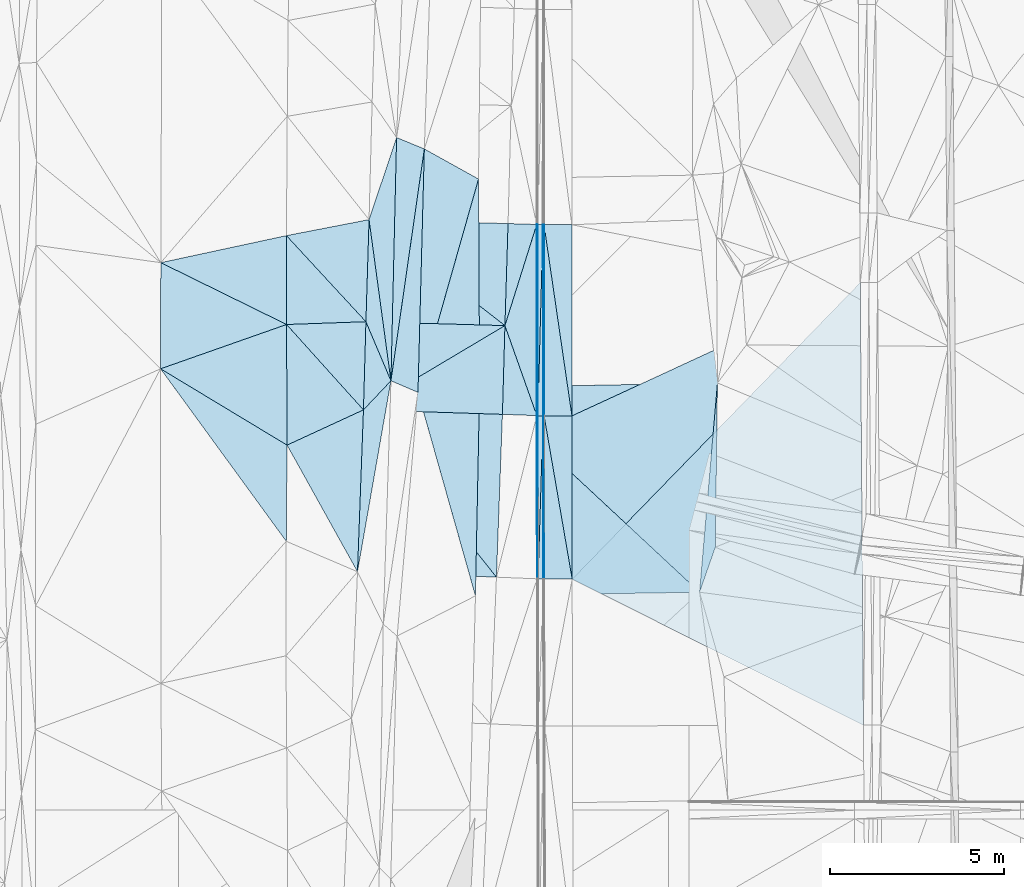
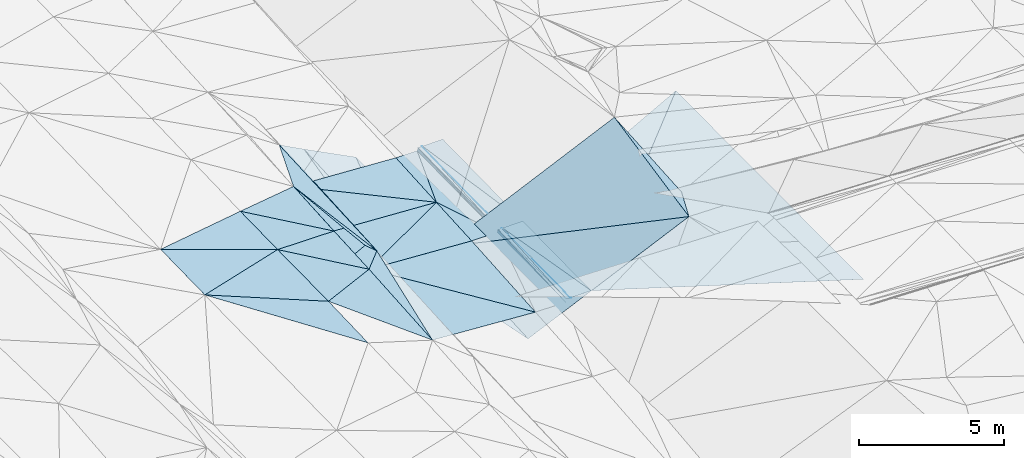
# One storey, part 110 of 275: 46 plates.
"""IFC2X3 building model written with IfcOpenShell, lengths in millimetres."""

from ifc_helpers import new_model, si_unit, frame, origin_with_axes, place, context, subcontext, project, spatial, polyline, outline, extrude, material, type_object, element, save


model = new_model("IFC2X3")

# Units and contexts
model_context = context("Model", 3, precision=1e-05, world=origin_with_axes())
body_context = subcontext(model_context, "Body", "Model", "MODEL_VIEW")
ifc_project = project(units=[si_unit("LENGTHUNIT", "METRE", prefix="MILLI"), si_unit("AREAUNIT", "SQUARE_METRE"), si_unit("VOLUMEUNIT", "CUBIC_METRE"), si_unit("MASSUNIT", "GRAM", prefix="KILO"), si_unit("TIMEUNIT", "SECOND"), si_unit("PLANEANGLEUNIT", "RADIAN"), si_unit("SOLIDANGLEUNIT", "STERADIAN"), si_unit("THERMODYNAMICTEMPERATUREUNIT", "DEGREE_CELSIUS"), si_unit("LUMINOUSINTENSITYUNIT", "LUMEN")], contexts=[model_context])

# Site, building, storey
site_placement = place(None, origin_with_axes())
site = spatial("IfcSite", under=ifc_project, at=site_placement, CompositionType="ELEMENT")
building_placement = place(site_placement, origin_with_axes())
building = spatial("IfcBuilding", under=site, at=building_placement, Name="Undefined", CompositionType="ELEMENT")
storey_placement = place(building_placement, origin_with_axes())
storey = spatial("IfcBuildingStorey", under=building, at=storey_placement, Name="Undefined", CompositionType="ELEMENT", Elevation=0.0)

# Plates
ifc_material = material()
plate_type_1 = type_object("IfcPlateType", PredefinedType="NOTDEFINED")
plate_1_placement = place(storey_placement, frame((-62445.3177072304, 83277.9958132401, 42809.5003490646), z_axis=(-0.0315854140654683, 0.0199617095165951, -0.999301702075749), x_axis=(0.999078721407139, -0.0284310420091758, -0.0321462949925501)))
element("IfcPlate", 1, at=plate_1_placement, inside=storey, type_object=plate_type_1, material=ifc_material, Name="00_PR", context=body_context, shape_type="SweptSolid", body=[
    extrude(outline(polyline([(0.0, 0.0), (4002.07861328125, -1.1743395589292e-08), (3997.42602539063, 2937.28759765625), (0.0, 0.0)])), frame((-8.85201319254618e-08, 2.18876761149539e-07, -0.5000001331573), z_axis=(0.0, 0.0, 1.0), x_axis=(1.0, 0.0, 0.0)), (0.0, 0.0, 1.0), 1.0),
])
plate_type_2 = type_object("IfcPlateType", PredefinedType="NOTDEFINED")
plate_2_placement = place(storey_placement, frame((-58536.9111922059, 80228.8299726045, 42625.0563495492), z_axis=(-0.0317222719708012, 0.0197862345419208, -0.999300856791218), x_axis=(-0.999087756710588, 0.0279704329910599, 0.0322693239671747)))
element("IfcPlate", 2, at=plate_2_placement, inside=storey, type_object=plate_type_2, material=ifc_material, Name="00_PR", context=body_context, shape_type="SweptSolid", body=[
    extrude(outline(polyline([(0.0, 0.0), (4002.09814453125, -4.45288605988026e-09), (3996.07958984375, 2939.119140625), (0.0, 0.0)])), frame((-8.85201319254618e-08, 2.18876761149539e-07, -0.5000001331573), z_axis=(0.0, 0.0, 1.0), x_axis=(1.0, 0.0, 0.0)), (0.0, 0.0, 1.0), 1.0),
])
plate_type_3 = type_object("IfcPlateType", PredefinedType="NOTDEFINED")
plate_3_placement = place(storey_placement, frame((-58536.9111922059, 80228.8299726045, 42625.0563495492), z_axis=(-0.0317247257780146, 0.0197004845342248, -0.999302473069804), x_axis=(-0.859075985348122, -0.511559405203103, 0.0171879709797397)))
element("IfcPlate", 3, at=plate_3_placement, inside=storey, type_object=plate_type_3, material=ifc_material, Name="00_PR", context=body_context, shape_type="SweptSolid", body=[
    extrude(outline(polyline([(0.0, 0.0), (4736.9755859375, -1.73604348674417e-08), (3379.92553710938, 2143.103515625), (0.0, 0.0)])), frame((-8.85201319254618e-08, 2.18876761149539e-07, -0.5000001331573), z_axis=(0.0, 0.0, 1.0), x_axis=(1.0, 0.0, 0.0)), (0.0, 0.0, 1.0), 1.0),
])
plate_type_4 = type_object("IfcPlateType", PredefinedType="NOTDEFINED")
plate_4_placement = place(storey_placement, frame((-62606.3332485193, 77805.5853230835, 42706.4753447277), z_axis=(-0.0315997411073619, 0.0194903227634184, -0.999310554172488), x_axis=(0.859075985348976, 0.511559405201546, -0.0171879709834169)))
element("IfcPlate", 4, at=plate_4_placement, inside=storey, type_object=plate_type_4, material=ifc_material, Name="00_PR", context=body_context, shape_type="SweptSolid", body=[
    extrude(outline(polyline([(0.0, 0.0), (4736.9755859375, -1.73604348674417e-08), (3370.44311523438, 2158.02124023438), (0.0, 0.0)])), frame((-8.85201319254618e-08, 2.18876761149539e-07, -0.5000001331573), z_axis=(0.0, 0.0, 1.0), x_axis=(1.0, 0.0, 0.0)), (0.0, 0.0, 1.0), 1.0),
])
plate_type_5 = type_object("IfcPlateType", PredefinedType="NOTDEFINED")
plate_5_placement = place(storey_placement, frame((-62606.3332390002, 77805.5856066557, 42706.4753500687), z_axis=(-0.0315810358178752, 0.0200566956395045, -0.999299938525313), x_axis=(0.998955927695341, -0.0323869359934166, -0.032220193967445)))
element("IfcPlate", 5, at=plate_5_placement, inside=storey, type_object=plate_type_5, material=ifc_material, Name="00_PR", context=body_context, shape_type="SweptSolid", body=[
    extrude(outline(polyline([(0.0, 0.0), (4002.11743164063, -7.84348230808973e-09), (3984.26293945313, 4687.0849609375), (0.0, 0.0)])), frame((-8.85201319254618e-08, 2.18876761149539e-07, -0.5000001331573), z_axis=(0.0, 0.0, 1.0), x_axis=(1.0, 0.0, 0.0)), (0.0, 0.0, 1.0), 1.0),
])
plate_type_6 = type_object("IfcPlateType", PredefinedType="NOTDEFINED")
plate_6_placement = place(storey_placement, frame((-57621.6868483666, 83138.9228194807, 42706.2017387824), z_axis=(0.970132635140627, 0.00490317513486907, -0.242525522592367), x_axis=(0.24230420795389, -0.0668225649493554, 0.967896386821145)))
element("IfcPlate", 6, at=plate_6_placement, inside=storey, type_object=plate_type_6, material=ifc_material, Name="00_PR", context=body_context, shape_type="SweptSolid", body=[
    extrude(outline(polyline([(0.0, 0.0), (123.791145324707, 3.05590219795704e-10), (273.008209228516, 5493.51953125), (0.0, 0.0)])), frame((-8.85201319254618e-08, 2.18876761149539e-07, -0.5000001331573), z_axis=(0.0, 0.0, 1.0), x_axis=(1.0, 0.0, 0.0)), (0.0, 0.0, 1.0), 1.0),
])
plate_type_7 = type_object("IfcPlateType", PredefinedType="NOTDEFINED")
plate_7_placement = place(storey_placement, frame((-57442.1709183714, 83130.164079048, 42825.6400820287), z_axis=(5.89384525256398e-05, 0.0179256504627519, -0.999839320881984), x_axis=(-0.0267601369903084, -0.999481235296596, -0.0179208079686884)))
element("IfcPlate", 7, at=plate_7_placement, inside=storey, type_object=plate_type_7, material=ifc_material, Name="00_PR", context=body_context, shape_type="SweptSolid", body=[
    extrude(outline(polyline([(0.0, 0.0), (5498.6357421875, 2.43016984313726e-09), (3.52122259140015, 149.96533203125), (0.0, 0.0)])), frame((-8.85201319254618e-08, 2.18876761149539e-07, -0.5000001331573), z_axis=(0.0, 0.0, 1.0), x_axis=(1.0, 0.0, 0.0)), (0.0, 0.0, 1.0), 1.0),
])
plate_8_placement = place(storey_placement, frame((-57438.9691726455, 77630.850453566, 42727.1000792408), z_axis=(0.000413148946733907, 0.0175960180344832, -0.999845092730508), x_axis=(-0.0305274379987929, -0.999378957367669, -0.0176004289703739)))
element("IfcPlate", 8, at=plate_8_placement, inside=storey, type_object=plate_type_7, material=ifc_material, Name="00_PR", context=body_context, shape_type="SweptSolid", body=[
    extrude(outline(polyline([(0.0, 0.0), (4695.51025390625, -1.80443748831749e-09), (1.0617915391922, 150.383514404297), (0.0, 0.0)])), frame((-8.85201319254618e-08, 2.18876761149539e-07, -0.5000001331573), z_axis=(0.0, 0.0, 1.0), x_axis=(1.0, 0.0, 0.0)), (0.0, 0.0, 1.0), 1.0),
])
plate_9_placement = place(storey_placement, frame((-57589.3149893711, 77634.3806865003, 42727.1000829347), z_axis=(0.000420660970530861, 0.0179159672540696, -0.999839407685904), x_axis=(0.0267601369728384, 0.999481235297007, 0.0179208079718514)))
element("IfcPlate", 9, at=plate_9_placement, inside=storey, type_object=plate_type_7, material=ifc_material, Name="00_PR", context=body_context, shape_type="SweptSolid", body=[
    extrude(outline(polyline([(0.0, 0.0), (5498.6357421875, 2.43016984313726e-09), (0.495032548904419, 150.386444091797), (0.0, 0.0)])), frame((-8.85201319254618e-08, 2.18876761149539e-07, -0.5000001331573), z_axis=(0.0, 0.0, 1.0), x_axis=(1.0, 0.0, 0.0)), (0.0, 0.0, 1.0), 1.0),
])
plate_10_placement = place(storey_placement, frame((-57582.3112025152, 72938.256117177, 42644.4570800898), z_axis=(0.000165261124698532, 0.0176035890359475, -0.999845031163237), x_axis=(0.0305274379744669, 0.999378957368358, 0.0176004289734247)))
element("IfcPlate", 10, at=plate_10_placement, inside=storey, type_object=plate_type_7, material=ifc_material, Name="00_PR", context=body_context, shape_type="SweptSolid", body=[
    extrude(outline(polyline([(0.0, 0.0), (4695.51025390625, -1.80443748831749e-09), (3.17336273193359, 150.046966552734), (0.0, 0.0)])), frame((-8.85201319254618e-08, 2.18876761149539e-07, -0.5000001331573), z_axis=(0.0, 0.0, 1.0), x_axis=(1.0, 0.0, 0.0)), (0.0, 0.0, 1.0), 1.0),
])
plate_type_8 = type_object("IfcPlateType", PredefinedType="NOTDEFINED")
plate_11_placement = place(storey_placement, frame((-57412.1606591374, 83130.1678266421, 42826.2401807814), z_axis=(0.0199903537948157, 0.0179238670003868, -0.999639495391669), x_axis=(0.000582077023911747, -0.999839329562212, -0.0179158099712417)))
element("IfcPlate", 11, at=plate_11_placement, inside=storey, type_object=plate_type_8, material=ifc_material, Name="00_PR", context=body_context, shape_type="SweptSolid", body=[
    extrude(outline(polyline([(0.0, 0.0), (5500.169921875, -1.15178409032524e-08), (-0.00296620349399745, 30.0062942504883), (0.0, 0.0)])), frame((-8.85201319254618e-08, 2.18876761149539e-07, -0.5000001331573), z_axis=(0.0, 0.0, 1.0), x_axis=(1.0, 0.0, 0.0)), (0.0, 0.0, 1.0), 1.0),
])
plate_12_placement = place(storey_placement, frame((-57438.9593939027, 77630.8506163562, 42727.1001824236), z_axis=(0.0199741401845531, 0.0179238633719823, -0.99963981955788), x_axis=(-0.000582077026000538, 0.999839329562174, 0.0179158099732483)))
element("IfcPlate", 12, at=plate_12_placement, inside=storey, type_object=plate_type_8, material=ifc_material, Name="00_PR", context=body_context, shape_type="SweptSolid", body=[
    extrude(outline(polyline([(0.0, 0.0), (5500.197265625, 1.87355908565223e-08), (0.0243410114198923, 30.006254196167), (0.0, 0.0)])), frame((-8.85201319254618e-08, 2.18876761149539e-07, -0.5000001331573), z_axis=(0.0, 0.0, 1.0), x_axis=(1.0, 0.0, 0.0)), (0.0, 0.0, 1.0), 1.0),
])
plate_13_placement = place(storey_placement, frame((-57432.2273950733, 72936.8472443817, 42644.4571798821), z_axis=(0.0199607529985949, 0.0176285553389435, -0.999645338295733), x_axis=(-0.00143400902612084, 0.999844019358452, 0.0176034249863106)))
element("IfcPlate", 13, at=plate_13_placement, inside=storey, type_object=plate_type_8, material=ifc_material, Name="00_PR", context=body_context, shape_type="SweptSolid", body=[
    extrude(outline(polyline([(0.0, 0.0), (4694.7353515625, -2.56914063356817e-08), (0.0227603428065777, 30.0065383911133), (0.0, 0.0)])), frame((-8.85201319254618e-08, 2.18876761149539e-07, -0.5000001331573), z_axis=(0.0, 0.0, 1.0), x_axis=(1.0, 0.0, 0.0)), (0.0, 0.0, 1.0), 1.0),
])
plate_type_9 = type_object("IfcPlateType", PredefinedType="NOTDEFINED")
plate_14_placement = place(storey_placement, frame((-62777.9336882094, 73148.5209642545, 42619.5003912758), z_axis=(-0.0343608174188855, 0.0205760651535635, -0.999197658008215), x_axis=(0.0368151613526759, 0.999135533976908, 0.0193087710446821)))
element("IfcPlate", 14, at=plate_14_placement, inside=storey, type_object=plate_type_9, material=ifc_material, Name="00", context=body_context, shape_type="SweptSolid", body=[
    extrude(outline(polyline([(0.0, 0.0), (4661.09423828125, -3.13593773171306e-08), (5524.3896484375, 760.051635742188), (0.0, 0.0)])), frame((-8.85201319254618e-08, 2.18876761149539e-07, -0.5000001331573), z_axis=(0.0, 0.0, 1.0), x_axis=(1.0, 0.0, 0.0)), (0.0, 0.0, 1.0), 1.0),
])
plate_type_10 = type_object("IfcPlateType", PredefinedType="NOTDEFINED")
plate_15_placement = place(storey_placement, frame((-58536.8796844866, 80228.82903207, 42625.0563252699), z_axis=(0.0312885211238499, 0.0179011582431978, -0.999350077289953), x_axis=(0.299757488876868, 0.953648213534751, 0.0264675779815947)))
element("IfcPlate", 15, at=plate_15_placement, inside=storey, type_object=plate_type_10, material=ifc_material, Name="00_PR", context=body_context, shape_type="SweptSolid", body=[
    extrude(outline(polyline([(0.0, 0.0), (3051.544921875, -1.43772922456265e-08), (-2194.61279296875, 1652.61083984375), (0.0, 0.0)])), frame((-8.85201319254618e-08, 2.18876761149539e-07, -0.5000001331573), z_axis=(0.0, 0.0, 1.0), x_axis=(1.0, 0.0, 0.0)), (0.0, 0.0, 1.0), 1.0),
])
plate_type_11 = type_object("IfcPlateType", PredefinedType="NOTDEFINED")
plate_16_placement = place(storey_placement, frame((-57618.9634509243, 77639.5114144846, 42607.4133171386), z_axis=(0.0308418574531809, 0.0177429290790511, -0.999366783666804), x_axis=(-0.998866829280015, 0.0368055550354608, -0.0301729760319002)))
element("IfcPlate", 16, at=plate_16_placement, inside=storey, type_object=plate_type_11, material=ifc_material, Name="00_PR", context=body_context, shape_type="SweptSolid", body=[
    extrude(outline(polyline([(0.0, 0.0), (990.522094726563, -2.8085196390748e-09), (1011.64520263672, 2554.21630859375), (0.0, 0.0)])), frame((-8.85201319254618e-08, 2.18876761149539e-07, -0.5000001331573), z_axis=(0.0, 0.0, 1.0), x_axis=(1.0, 0.0, 0.0)), (0.0, 0.0, 1.0), 1.0),
])
plate_type_12 = type_object("IfcPlateType", PredefinedType="NOTDEFINED")
plate_17_placement = place(storey_placement, frame((-61653.2734745281, 85638.8519640096, 42845.5001881095), z_axis=(-0.0179682444485179, 0.0212709194481109, -0.999612269921328), x_axis=(-0.0231638574708815, -0.999514187364314, -0.0208524570380708)))
element("IfcPlate", 17, at=plate_17_placement, inside=storey, type_object=plate_type_12, material=ifc_material, Name="00", context=body_context, shape_type="SweptSolid", body=[
    extrude(outline(polyline([(0.0, 0.0), (7001.5732421875, 1.62908690981567e-08), (2378.80590820313, 737.252075195313), (0.0, 0.0)])), frame((-8.85201319254618e-08, 2.18876761149539e-07, -0.5000001331573), z_axis=(0.0, 0.0, 1.0), x_axis=(1.0, 0.0, 0.0)), (0.0, 0.0, 1.0), 1.0),
])
plate_type_13 = type_object("IfcPlateType", PredefinedType="NOTDEFINED")
plate_18_placement = place(storey_placement, frame((-58780.953297902, 72992.8645551217, 42488.9863514636), z_axis=(-0.0316714713469708, 0.0199847488422636, -0.99929851781959), x_axis=(-0.998716945625713, 0.0388934670209276, 0.0324308609682016)))
element("IfcPlate", 18, at=plate_18_placement, inside=storey, type_object=plate_type_13, material=ifc_material, Name="00_PR", context=body_context, shape_type="SweptSolid", body=[
    extrude(outline(polyline([(0.0, 0.0), (4002.11376953125, 1.0986695997417e-08), (4014.70849609375, 4661.033203125), (0.0, 0.0)])), frame((-8.85201319254618e-08, 2.18876761149539e-07, -0.5000001331573), z_axis=(0.0, 0.0, 1.0), x_axis=(1.0, 0.0, 0.0)), (0.0, 0.0, 1.0), 1.0),
])
plate_type_14 = type_object("IfcPlateType", PredefinedType="NOTDEFINED")
plate_19_placement = place(storey_placement, frame((-48315.5027158374, 81465.7256772161, 42977.9691787994), z_axis=(0.0199746350867167, 0.0177399018565916, -0.999643091225699), x_axis=(0.00717853003015854, -0.999819345250477, -0.0175995900382054)))
element("IfcPlate", 19, at=plate_19_placement, inside=storey, type_object=plate_type_14, material=ifc_material, Name="00_PR", context=body_context, shape_type="SweptSolid", body=[
    extrude(outline(polyline([(0.0, 0.0), (12734.5009765625, 5.47734089195728e-08), (8471.9130859375, 8349.4228515625), (0.0, 0.0)])), frame((-8.85201319254618e-08, 2.18876761149539e-07, -0.5000001331573), z_axis=(0.0, 0.0, 1.0), x_axis=(1.0, 0.0, 0.0)), (0.0, 0.0, 1.0), 1.0),
])
plate_type_15 = type_object("IfcPlateType", PredefinedType="NOTDEFINED")
plate_20_placement = place(storey_placement, frame((-56612.1606702907, 83130.2649938498, 42842.240181095), z_axis=(0.0199906118117103, 0.0179262639094457, -0.999639447251679), x_axis=(0.000581992979138998, -0.999839286621116, -0.0179182089827727)))
element("IfcPlate", 20, at=plate_20_placement, inside=storey, type_object=plate_type_15, material=ifc_material, Name="00_PR", context=body_context, shape_type="SweptSolid", body=[
    extrude(outline(polyline([(0.0, 0.0), (5499.43359375, -1.13941496238112e-08), (-0.0817527920007706, 800.159973144531), (0.0, 0.0)])), frame((-8.85201319254618e-08, 2.18876761149539e-07, -0.5000001331573), z_axis=(0.0, 0.0, 1.0), x_axis=(1.0, 0.0, 0.0)), (0.0, 0.0, 1.0), 1.0),
])
plate_21_placement = place(storey_placement, frame((-56608.9600476809, 77631.7152347256, 42743.7001784185), z_axis=(0.019974549832582, 0.0176309226597535, -0.999645020957516), x_axis=(0.00143405198738597, -0.999843977884378, -0.0176057769848715)))
element("IfcPlate", 21, at=plate_21_placement, inside=storey, type_object=plate_type_15, material=ifc_material, Name="00_PR", context=body_context, shape_type="SweptSolid", body=[
    extrude(outline(polyline([(0.0, 0.0), (4694.083984375, -9.2186382971704e-09), (-0.0319749563932419, 800.159484863281), (0.0, 0.0)])), frame((-8.85201319254618e-08, 2.18876761149539e-07, -0.5000001331573), z_axis=(0.0, 0.0, 1.0), x_axis=(1.0, 0.0, 0.0)), (0.0, 0.0, 1.0), 1.0),
])
plate_22_placement = place(storey_placement, frame((-57408.9591456549, 77630.8816770682, 42727.7001808687), z_axis=(0.0199741401845531, 0.0179238633719823, -0.99963981955788), x_axis=(-0.000582077026000538, 0.999839329562174, 0.0179158099732483)))
element("IfcPlate", 22, at=plate_22_placement, inside=storey, type_object=plate_type_15, material=ifc_material, Name="00_PR", context=body_context, shape_type="SweptSolid", body=[
    extrude(outline(polyline([(0.0, 0.0), (5500.169921875, -1.15178409032524e-08), (0.654560685157776, 800.159240722656), (0.0, 0.0)])), frame((-8.85201319254618e-08, 2.18876761149539e-07, -0.5000001331573), z_axis=(0.0, 0.0, 1.0), x_axis=(1.0, 0.0, 0.0)), (0.0, 0.0, 1.0), 1.0),
])
plate_23_placement = place(storey_placement, frame((-57402.2269020101, 72936.9025004294, 42645.0571785886), z_axis=(0.0199607529985949, 0.0176285553389435, -0.999645338295733), x_axis=(-0.00143400902612084, 0.999844019358452, 0.0176034249863106)))
element("IfcPlate", 23, at=plate_23_placement, inside=storey, type_object=plate_type_15, material=ifc_material, Name="00_PR", context=body_context, shape_type="SweptSolid", body=[
    extrude(outline(polyline([(0.0, 0.0), (4694.71142578125, 1.03318598121405e-08), (0.59520697593689, 800.159484863281), (0.0, 0.0)])), frame((-8.85201319254618e-08, 2.18876761149539e-07, -0.5000001331573), z_axis=(0.0, 0.0, 1.0), x_axis=(1.0, 0.0, 0.0)), (0.0, 0.0, 1.0), 1.0),
])
plate_type_16 = type_object("IfcPlateType", PredefinedType="NOTDEFINED")
plate_24_placement = place(storey_placement, frame((-56602.2284332541, 72938.3634596855, 42661.0571794938), z_axis=(0.0200866421434011, 0.0176310438425496, -0.999642772744556), x_axis=(-0.00143405199437201, 0.999843977884384, 0.0176057769839547)))
element("IfcPlate", 24, at=plate_24_placement, inside=storey, type_object=plate_type_16, material=ifc_material, Name="00_PR", context=body_context, shape_type="SweptSolid", body=[
    extrude(outline(polyline([(0.0, 0.0), (4694.083984375, -9.2186382971704e-09), (8519.7275390625, 8300.626953125), (0.0, 0.0)])), frame((-8.85201319254618e-08, 2.18876761149539e-07, -0.5000001331573), z_axis=(0.0, 0.0, 1.0), x_axis=(1.0, 0.0, 0.0)), (0.0, 0.0, 1.0), 1.0),
])
plate_type_17 = type_object("IfcPlateType", PredefinedType="NOTDEFINED")
plate_25_placement = place(storey_placement, frame((-57618.4935387309, 77639.5049537193, 42607.7928165393), z_axis=(0.970669872255005, 0.00481481324952325, -0.240368085797231), x_axis=(0.00487705397550587, 0.999199352706721, 0.0397097959575397)))
element("IfcPlate", 25, at=plate_25_placement, inside=storey, type_object=plate_type_17, material=ifc_material, Name="00_PR", context=body_context, shape_type="SweptSolid", body=[
    extrude(outline(polyline([(0.0, 0.0), (5495.5458984375, 3.20251274388283e-08), (-0.229290172457695, 123.414688110352), (0.0, 0.0)])), frame((-8.85201319254618e-08, 2.18876761149539e-07, -0.5000001331573), z_axis=(0.0, 0.0, 1.0), x_axis=(1.0, 0.0, 0.0)), (0.0, 0.0, 1.0), 1.0),
])
plate_26_placement = place(storey_placement, frame((-57588.8298611335, 77634.374543891, 42727.4798348147), z_axis=(0.970673892886174, 0.00563007462333887, -0.240334133923867), x_axis=(-0.0048865979847701, -0.99905707824968, -0.0431401849711931)))
element("IfcPlate", 26, at=plate_26_placement, inside=storey, type_object=plate_type_17, material=ifc_material, Name="00_PR", context=body_context, shape_type="SweptSolid", body=[
    extrude(outline(polyline([(0.0, 0.0), (4693.90673828125, 2.06455297302455e-08), (0.182295963168144, 123.414764404297), (0.0, 0.0)])), frame((-8.85201319254618e-08, 2.18876761149539e-07, -0.5000001331573), z_axis=(0.0, 0.0, 1.0), x_axis=(1.0, 0.0, 0.0)), (0.0, 0.0, 1.0), 1.0),
])
plate_type_18 = type_object("IfcPlateType", PredefinedType="NOTDEFINED")
plate_27_placement = place(storey_placement, frame((-57622.1565060754, 83138.929393828, 42705.8233191055), z_axis=(0.0308163268850978, 0.0180499146264711, -0.999362073814735), x_axis=(-0.299757488826495, -0.953648213551149, -0.0264675779612603)))
element("IfcPlate", 27, at=plate_27_placement, inside=storey, type_object=plate_type_18, material=ifc_material, Name="00_PR", context=body_context, shape_type="SweptSolid", body=[
    extrude(outline(polyline([(0.0, 0.0), (3051.544921875, -1.43772922456265e-08), (223.772232055664, 794.595764160156), (0.0, 0.0)])), frame((-8.85201319254618e-08, 2.18876761149539e-07, -0.5000001331573), z_axis=(0.0, 0.0, 1.0), x_axis=(1.0, 0.0, 0.0)), (0.0, 0.0, 1.0), 1.0),
])
plate_28_placement = place(storey_placement, frame((-60854.9814031236, 85311.7670170099, 42583.5244037562), z_axis=(-0.307417830822706, 0.0277280302770093, -0.951170559694327), x_axis=(-0.026118208484216, -0.999444646635945, -0.0206938999786211)))
element("IfcPlate", 28, at=plate_28_placement, inside=storey, type_object=plate_type_18, material=ifc_material, Name="00", context=body_context, shape_type="SweptSolid", body=[
    extrude(outline(polyline([(0.0, 0.0), (7006.8955078125, -4.80213202536106e-10), (6690.06787109375, 826.192504882813), (0.0, 0.0)])), frame((-8.85201319254618e-08, 2.18876761149539e-07, -0.5000001331573), z_axis=(0.0, 0.0, 1.0), x_axis=(1.0, 0.0, 0.0)), (0.0, 0.0, 1.0), 1.0),
])
plate_type_19 = type_object("IfcPlateType", PredefinedType="NOTDEFINED")
plate_29_placement = place(storey_placement, frame((-68442.2730968123, 78986.7242215902, 42959.5006060431), z_axis=(-0.0455134974661261, 0.0197170673501323, -0.998769121871272), x_axis=(0.00196292241063431, 0.99980503117234, 0.0196480680496977)))
element("IfcPlate", 29, at=plate_29_placement, inside=storey, type_object=plate_type_19, material=ifc_material, Name="00", context=body_context, shape_type="SweptSolid", body=[
    extrude(outline(polyline([(0.0, 0.0), (3053.7353515625, -1.68511178344488e-08), (1278.36877441406, 3625.50317382813), (0.0, 0.0)])), frame((-8.85201319254618e-08, 2.18876761149539e-07, -0.5000001331573), z_axis=(0.0, 0.0, 1.0), x_axis=(1.0, 0.0, 0.0)), (0.0, 0.0, 1.0), 1.0),
])
plate_type_20 = type_object("IfcPlateType", PredefinedType="NOTDEFINED")
plate_30_placement = place(storey_placement, frame((-64818.0174515854, 80260.9765094898, 42819.5003026234), z_axis=(-0.0312285293030029, 0.0166423327778597, -0.999373709738896), x_axis=(0.998920592393078, 0.0349181376825914, -0.0306328868022973)))
element("IfcPlate", 30, at=plate_30_placement, inside=storey, type_object=plate_type_20, material=ifc_material, Name="00", context=body_context, shape_type="SweptSolid", body=[
    extrude(outline(polyline([(0.0, 0.0), (2285.12573242188, -7.8580342233181e-09), (2126.92895507813, 2531.5556640625), (0.0, 0.0)])), frame((-8.85201319254618e-08, 2.18876761149539e-07, -0.5000001331573), z_axis=(0.0, 0.0, 1.0), x_axis=(1.0, 0.0, 0.0)), (0.0, 0.0, 1.0), 1.0),
])
plate_type_21 = type_object("IfcPlateType", PredefinedType="NOTDEFINED")
plate_31_placement = place(storey_placement, frame((-61815.5987967637, 78640.68318529, 42699.5234815824), z_axis=(-0.301715330255878, 0.0268747390340944, -0.95301920646461), x_axis=(0.0231638574559472, 0.999514187364994, 0.0208524570220463)))
element("IfcPlate", 31, at=plate_31_placement, inside=storey, type_object=plate_type_21, material=ifc_material, Name="00", context=body_context, shape_type="SweptSolid", body=[
    extrude(outline(polyline([(0.0, 0.0), (7001.5732421875, 1.62908690981567e-08), (6687.67529296875, 845.340270996094), (0.0, 0.0)])), frame((-8.85201319254618e-08, 2.18876761149539e-07, -0.5000001331573), z_axis=(0.0, 0.0, 1.0), x_axis=(1.0, 0.0, 0.0)), (0.0, 0.0, 1.0), 1.0),
])
plate_type_22 = type_object("IfcPlateType", PredefinedType="NOTDEFINED")
plate_32_placement = place(storey_placement, frame((-52937.6920698922, 72560.1153467127, 44715.5009709032), z_axis=(0.0328917600084741, 0.053236451869442, -0.998040085525575), x_axis=(0.0849899013428397, 0.994814444674789, 0.055865350049248)))
element("IfcPlate", 32, at=plate_32_placement, inside=storey, type_object=plate_type_22, material=ifc_material, Name="00", context=body_context, shape_type="SweptSolid", body=[
    extrude(outline(polyline([(0.0, 0.0), (6050.26171875, 4.16985130868852e-08), (1331.28796386719, 341.428314208984), (0.0, 0.0)])), frame((-8.85201319254618e-08, 2.18876761149539e-07, -0.5000001331573), z_axis=(0.0, 0.0, 1.0), x_axis=(1.0, 0.0, 0.0)), (0.0, 0.0, 1.0), 1.0),
])
plate_type_23 = type_object("IfcPlateType", PredefinedType="NOTDEFINED")
plate_33_placement = place(storey_placement, frame((-62445.3119250355, 83277.9963780348, 42809.5001991414), z_axis=(-0.0197732074240157, 0.021025079258771, -0.999583396375875), x_axis=(0.134550068700052, -0.990628138300088, -0.0234983110225826)))
element("IfcPlate", 33, at=plate_33_placement, inside=storey, type_object=plate_type_23, material=ifc_material, Name="00", context=body_context, shape_type="SweptSolid", body=[
    extrude(outline(polyline([(0.0, 0.0), (4681.1875, -3.38695826940238e-08), (2898.99291992188, 484.602478027344), (0.0, 0.0)])), frame((-8.85201319254618e-08, 2.18876761149539e-07, -0.5000001331573), z_axis=(0.0, 0.0, 1.0), x_axis=(1.0, 0.0, 0.0)), (0.0, 0.0, 1.0), 1.0),
])
plate_type_24 = type_object("IfcPlateType", PredefinedType="NOTDEFINED")
plate_34_placement = place(storey_placement, frame((-60854.9321956819, 85311.7660086369, 42583.5112002444), z_axis=(-0.208996394576721, 0.025702798751232, -0.977578576478784), x_axis=(0.857025950874515, -0.476640665310566, -0.195755448710719)))
element("IfcPlate", 34, at=plate_34_placement, inside=storey, type_object=plate_type_24, material=ifc_material, Name="00", context=body_context, shape_type="SweptSolid", body=[
    extrude(outline(polyline([(0.0, 0.0), (1818.59558105469, 2.51748133450747e-09), (3209.458984375, 6228.64013671875), (0.0, 0.0)])), frame((-8.85201319254618e-08, 2.18876761149539e-07, -0.5000001331573), z_axis=(0.0, 0.0, 1.0), x_axis=(1.0, 0.0, 0.0)), (0.0, 0.0, 1.0), 1.0),
])
plate_type_25 = type_object("IfcPlateType", PredefinedType="NOTDEFINED")
plate_35_placement = place(storey_placement, frame((-64818.0236967698, 80260.9798732159, 42819.5006041732), z_axis=(-0.0437181880478743, 0.0233688868162236, -0.998770551809965), x_axis=(-0.896305184326883, 0.440661385406876, 0.0495435158223967)))
element("IfcPlate", 35, at=plate_35_placement, inside=storey, type_object=plate_type_25, material=ifc_material, Name="00", context=body_context, shape_type="SweptSolid", body=[
    extrude(outline(polyline([(0.0, 0.0), (4036.85522460938, -2.16532498598099e-08), (1133.283203125, 2292.54638671875), (0.0, 0.0)])), frame((-8.85201319254618e-08, 2.18876761149539e-07, -0.5000001331573), z_axis=(0.0, 0.0, 1.0), x_axis=(1.0, 0.0, 0.0)), (0.0, 0.0, 1.0), 1.0),
])
plate_type_26 = type_object("IfcPlateType", PredefinedType="NOTDEFINED")
plate_36_placement = place(storey_placement, frame((-64827.2216185643, 74024.7291033656, 42689.500603134), z_axis=(-0.0443342351790377, 0.0220472377785364, -0.998773445230412), x_axis=(-0.588276832686232, 0.807465108850511, 0.0439370699260693)))
element("IfcPlate", 36, at=plate_36_placement, inside=storey, type_object=plate_type_26, material=ifc_material, Name="00", context=body_context, shape_type="SweptSolid", body=[
    extrude(outline(polyline([(0.0, 0.0), (6145.15234375, 1.79534254129976e-09), (2221.94653320313, 1648.19714355469), (0.0, 0.0)])), frame((-8.85201319254618e-08, 2.18876761149539e-07, -0.5000001331573), z_axis=(0.0, 0.0, 1.0), x_axis=(1.0, 0.0, 0.0)), (0.0, 0.0, 1.0), 1.0),
])
plate_type_27 = type_object("IfcPlateType", PredefinedType="NOTDEFINED")
plate_37_placement = place(storey_placement, frame((-64822.1372678327, 82817.6335652296, 42879.500387268), z_axis=(-0.0335805606611336, 0.0214406338554154, -0.999206007370633), x_axis=(0.981344011973647, 0.19007530665788, -0.0289016948011622)))
element("IfcPlate", 37, at=plate_37_placement, inside=storey, type_object=plate_type_27, material=ifc_material, Name="00", context=body_context, shape_type="SweptSolid", body=[
    extrude(outline(polyline([(0.0, 0.0), (2422.00341796875, 2.53203324973583e-09), (1777.08264160156, 2867.5908203125), (0.0, 0.0)])), frame((-8.85201319254618e-08, 2.18876761149539e-07, -0.5000001331573), z_axis=(0.0, 0.0, 1.0), x_axis=(1.0, 0.0, 0.0)), (0.0, 0.0, 1.0), 1.0),
])
plate_type_28 = type_object("IfcPlateType", PredefinedType="NOTDEFINED")
plate_38_placement = place(storey_placement, frame((-62535.3576918652, 80340.7688325003, 42749.5002873339), z_axis=(-0.0301792845275292, 0.0166134751499197, -0.999406425449051), x_axis=(0.389784414788794, -0.920508120179401, -0.0270723229801634)))
element("IfcPlate", 38, at=plate_38_placement, inside=storey, type_object=plate_type_28, material=ifc_material, Name="00", context=body_context, shape_type="SweptSolid", body=[
    extrude(outline(polyline([(0.0, 0.0), (1846.90466308594, 9.98261384665966e-09), (2307.076171875, 1054.13427734375), (0.0, 0.0)])), frame((-8.85201319254618e-08, 2.18876761149539e-07, -0.5000001331573), z_axis=(0.0, 0.0, 1.0), x_axis=(1.0, 0.0, 0.0)), (0.0, 0.0, 1.0), 1.0),
])
plate_type_29 = type_object("IfcPlateType", PredefinedType="NOTDEFINED")
plate_39_placement = place(storey_placement, frame((-59296.3441335258, 84444.948083593, 42227.510248687), z_axis=(-0.200144182444446, 0.0231244902253806, -0.97949352432033), x_axis=(0.00532034054356923, -0.999681042066249, -0.0246882180369266)))
element("IfcPlate", 39, at=plate_39_placement, inside=storey, type_object=plate_type_29, material=ifc_material, Name="00", context=body_context, shape_type="SweptSolid", body=[
    extrude(outline(polyline([(0.0, 0.0), (5994.76220703125, 3.98722477257252e-08), (6119.75537109375, 1810.81579589844), (0.0, 0.0)])), frame((-8.85201319254618e-08, 2.18876761149539e-07, -0.5000001331573), z_axis=(0.0, 0.0, 1.0), x_axis=(1.0, 0.0, 0.0)), (0.0, 0.0, 1.0), 1.0),
])
plate_type_30 = type_object("IfcPlateType", PredefinedType="NOTDEFINED")
plate_40_placement = place(storey_placement, frame((-62535.3583317025, 80340.7722253142, 42749.5003750145), z_axis=(-0.0314603554115452, 0.0233994405482538, -0.999231060475708), x_axis=(-0.998920592393369, -0.034918137662468, 0.0306328868157338)))
element("IfcPlate", 40, at=plate_40_placement, inside=storey, type_object=plate_type_30, material=ifc_material, Name="00", context=body_context, shape_type="SweptSolid", body=[
    extrude(outline(polyline([(0.0, 0.0), (2285.12573242188, -7.8580342233181e-09), (2201.80444335938, 2556.00415039063), (0.0, 0.0)])), frame((-8.85201319254618e-08, 2.18876761149539e-07, -0.5000001331573), z_axis=(0.0, 0.0, 1.0), x_axis=(1.0, 0.0, 0.0)), (0.0, 0.0, 1.0), 1.0),
])
plate_type_31 = type_object("IfcPlateType", PredefinedType="NOTDEFINED")
plate_41_placement = place(storey_placement, frame((-59264.4502872877, 78452.1023588625, 42079.5104457765), z_axis=(-0.200804457136792, 0.0322812344649197, -0.97909932687926), x_axis=(-0.0200844834459443, -0.99938250770501, -0.0288308310313138)))
element("IfcPlate", 41, at=plate_41_placement, inside=storey, type_object=plate_type_31, material=ifc_material, Name="00", context=body_context, shape_type="SweptSolid", body=[
    extrude(outline(polyline([(0.0, 0.0), (6000.52099609375, 9.16770659387112e-10), (168.518203735352, 1807.28491210938), (0.0, 0.0)])), frame((-8.85201319254618e-08, 2.18876761149539e-07, -0.5000001331573), z_axis=(0.0, 0.0, 1.0), x_axis=(1.0, 0.0, 0.0)), (0.0, 0.0, 1.0), 1.0),
])
plate_type_32 = type_object("IfcPlateType", PredefinedType="NOTDEFINED")
plate_42_placement = place(storey_placement, frame((-64803.5069468349, 76790.4899883969, 42749.5002829896), z_axis=(-0.0275872563525769, 0.0203306335699022, -0.999412631812098), x_axis=(0.90767584638932, 0.419346517448862, -0.0165244117881252)))
element("IfcPlate", 42, at=plate_42_placement, inside=storey, type_object=plate_type_32, material=ifc_material, Name="00", context=body_context, shape_type="SweptSolid", body=[
    extrude(outline(polyline([(0.0, 0.0), (2420.6611328125, 4.65661287307739e-09), (313.468078613281, 4157.587890625), (0.0, 0.0)])), frame((-8.85201319254618e-08, 2.18876761149539e-07, -0.5000001331573), z_axis=(0.0, 0.0, 1.0), x_axis=(1.0, 0.0, 0.0)), (0.0, 0.0, 1.0), 1.0),
])
plate_type_33 = type_object("IfcPlateType", PredefinedType="NOTDEFINED")
plate_43_placement = place(storey_placement, frame((-64803.5159510061, 76790.4898003762, 42749.5006089357), z_axis=(-0.0455966316084635, 0.0199544526543252, -0.998760615465602), x_axis=(-0.855099463340428, 0.516110001429976, 0.0493495108269856)))
element("IfcPlate", 43, at=plate_43_placement, inside=storey, type_object=plate_type_33, material=ifc_material, Name="00", context=body_context, shape_type="SweptSolid", body=[
    extrude(outline(polyline([(0.0, 0.0), (4255.361328125, -9.45146894082427e-09), (1807.0146484375, 2963.7978515625), (0.0, 0.0)])), frame((-8.85201319254618e-08, 2.18876761149539e-07, -0.5000001331573), z_axis=(0.0, 0.0, 1.0), x_axis=(1.0, 0.0, 0.0)), (0.0, 0.0, 1.0), 1.0),
])
plate_type_34 = type_object("IfcPlateType", PredefinedType="NOTDEFINED")
plate_44_placement = place(storey_placement, frame((-62606.3313025895, 77805.5856324624, 42709.5002805459), z_axis=(-0.0274548361996775, 0.020043637921822, -0.99942207527556), x_axis=(-0.907675846418242, -0.419346517386041, 0.0165244117936861)))
element("IfcPlate", 44, at=plate_44_placement, inside=storey, type_object=plate_type_34, material=ifc_material, Name="00", context=body_context, shape_type="SweptSolid", body=[
    extrude(outline(polyline([(0.0, 0.0), (2420.6611328125, 4.65661287307739e-09), (979.649719238281, 3157.98779296875), (0.0, 0.0)])), frame((-8.85201319254618e-08, 2.18876761149539e-07, -0.5000001331573), z_axis=(0.0, 0.0, 1.0), x_axis=(1.0, 0.0, 0.0)), (0.0, 0.0, 1.0), 1.0),
])
plate_type_35 = type_object("IfcPlateType", PredefinedType="NOTDEFINED")
plate_45_placement = place(storey_placement, frame((-59384.6676970283, 72455.2799031878, 41906.5416328602), z_axis=(0.399110496134953, 0.0184251820681357, -0.91671769075363), x_axis=(0.020084483436108, 0.999382507706357, 0.0288308309914596)))
element("IfcPlate", 45, at=plate_45_placement, inside=storey, type_object=plate_type_35, material=ifc_material, Name="00", context=body_context, shape_type="SweptSolid", body=[
    extrude(outline(polyline([(0.0, 0.0), (6000.52099609375, 9.16770659387112e-10), (315.226959228516, 7026.2333984375), (0.0, 0.0)])), frame((-8.85201319254618e-08, 2.18876761149539e-07, -0.5000001331573), z_axis=(0.0, 0.0, 1.0), x_axis=(1.0, 0.0, 0.0)), (0.0, 0.0, 1.0), 1.0),
])
plate_type_36 = type_object("IfcPlateType", PredefinedType="NOTDEFINED")
plate_46_placement = place(storey_placement, frame((-52423.2982190319, 78578.9853892276, 45053.541462949), z_axis=(0.39836081487688, 0.0174659409501522, -0.917062485372373), x_axis=(-0.0849899013662938, -0.994814444675891, -0.0558653499939507)))
element("IfcPlate", 46, at=plate_46_placement, inside=storey, type_object=plate_type_36, material=ifc_material, Name="00", context=body_context, shape_type="SweptSolid", body=[
    extrude(outline(polyline([(0.0, 0.0), (6050.26171875, 4.16985130868852e-08), (873.779357910156, 7409.08544921875), (0.0, 0.0)])), frame((-8.85201319254618e-08, 2.18876761149539e-07, -0.5000001331573), z_axis=(0.0, 0.0, 1.0), x_axis=(1.0, 0.0, 0.0)), (0.0, 0.0, 1.0), 1.0),
])

save(model, "model.ifc")
